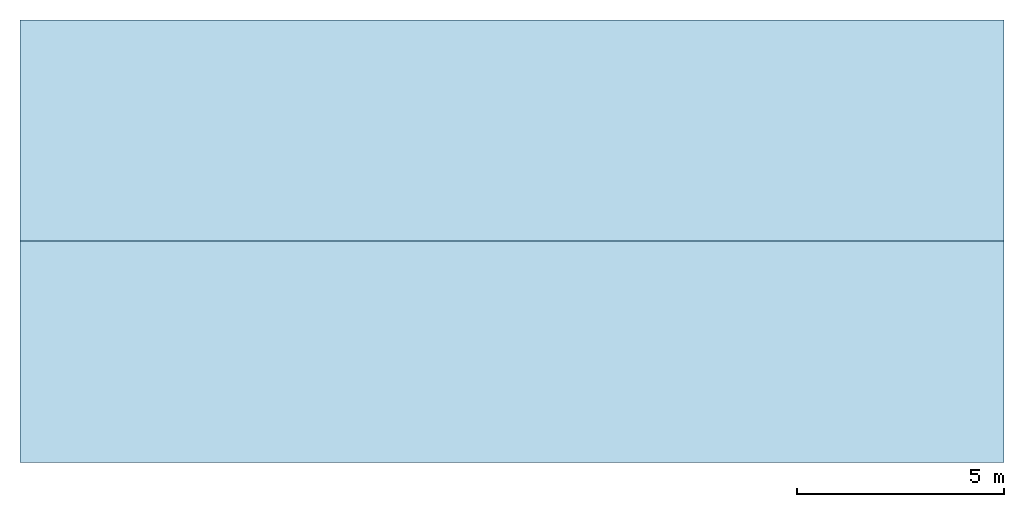
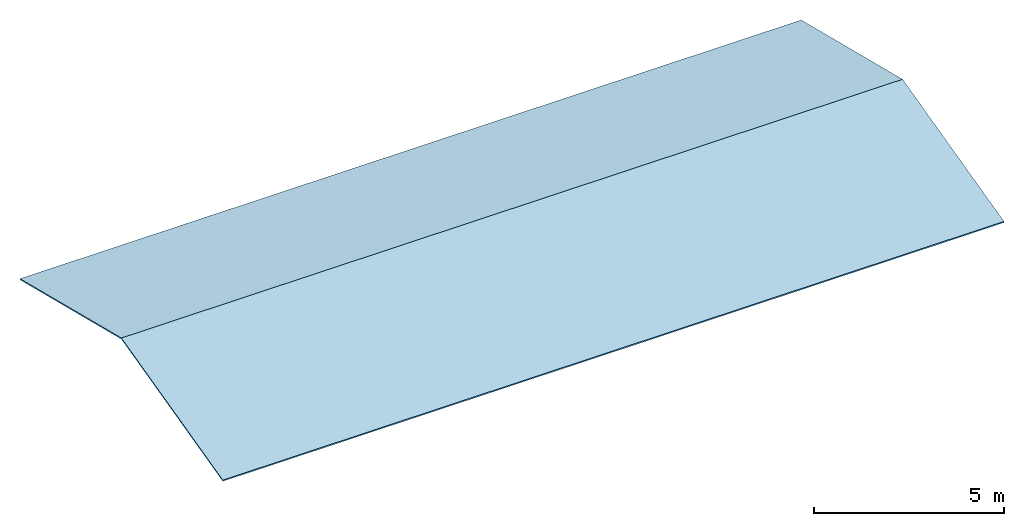
# One storey: 2 slabs, 1 element without a shape of its own.
"""IFC2X3 building model written with IfcOpenShell, lengths in millimetres."""

from ifc_helpers import new_model, entity, si_unit, converted_unit, derived_unit, direction, frame, frame_2d, origin, place, context, subcontext, project, spatial, rectangle, extrude, type_object, element, aggregate, save


model = new_model("IFC2X3")

# Units and contexts
model_context = context("Model", 3, precision=0.01, world=origin(), true_north=direction((6.12303176911189e-17, 1.0)))
body_context = subcontext(model_context, "Body", "Model", "MODEL_VIEW")
ifc_project = project(units=[si_unit("LENGTHUNIT", "METRE", prefix="MILLI"), si_unit("AREAUNIT", "SQUARE_METRE"), si_unit("VOLUMEUNIT", "CUBIC_METRE"), converted_unit("PLANEANGLEUNIT", "DEGREE", entity("IfcRatioMeasure", 0.0174532925199433), si_unit("PLANEANGLEUNIT", "RADIAN"), dimensions=[0, 0, 0, 0, 0, 0, 0]), si_unit("MASSUNIT", "GRAM", prefix="KILO"), derived_unit("MASSDENSITYUNIT", [(si_unit("MASSUNIT", "GRAM", prefix="KILO"), 1), (si_unit("LENGTHUNIT", "METRE"), -3)]), derived_unit("MOMENTOFINERTIAUNIT", [(si_unit("LENGTHUNIT", "METRE"), 4)]), si_unit("TIMEUNIT", "SECOND"), si_unit("FREQUENCYUNIT", "HERTZ"), si_unit("THERMODYNAMICTEMPERATUREUNIT", "DEGREE_CELSIUS"), derived_unit("THERMALTRANSMITTANCEUNIT", [(si_unit("MASSUNIT", "GRAM", prefix="KILO"), 1), (si_unit("THERMODYNAMICTEMPERATUREUNIT", "KELVIN"), -1), (si_unit("TIMEUNIT", "SECOND"), -3)]), derived_unit("VOLUMETRICFLOWRATEUNIT", [(si_unit("LENGTHUNIT", "METRE"), 3), (si_unit("TIMEUNIT", "SECOND"), -1)]), si_unit("ELECTRICCURRENTUNIT", "AMPERE"), si_unit("ELECTRICVOLTAGEUNIT", "VOLT"), si_unit("POWERUNIT", "WATT"), si_unit("FORCEUNIT", "NEWTON", prefix="KILO"), si_unit("ILLUMINANCEUNIT", "LUX"), si_unit("LUMINOUSFLUXUNIT", "LUMEN"), si_unit("LUMINOUSINTENSITYUNIT", "CANDELA"), derived_unit("USERDEFINED", [(si_unit("MASSUNIT", "GRAM", prefix="KILO"), -1), (si_unit("LENGTHUNIT", "METRE"), -2), (si_unit("TIMEUNIT", "SECOND"), 3), (si_unit("LUMINOUSFLUXUNIT", "LUMEN"), 1)]), derived_unit("LINEARVELOCITYUNIT", [(si_unit("LENGTHUNIT", "METRE"), 1), (si_unit("TIMEUNIT", "SECOND"), -1)]), si_unit("PRESSUREUNIT", "PASCAL"), derived_unit("USERDEFINED", [(si_unit("LENGTHUNIT", "METRE"), -2), (si_unit("MASSUNIT", "GRAM", prefix="KILO"), 1), (si_unit("TIMEUNIT", "SECOND"), -2)]), derived_unit("LINEARFORCEUNIT", [(si_unit("MASSUNIT", "GRAM", prefix="KILO"), 1), (si_unit("LENGTHUNIT", "METRE"), 1), (si_unit("TIMEUNIT", "SECOND"), -2), (si_unit("LENGTHUNIT", "METRE"), -1)]), derived_unit("PLANARFORCEUNIT", [(si_unit("MASSUNIT", "GRAM", prefix="KILO"), 1), (si_unit("LENGTHUNIT", "METRE"), 1), (si_unit("TIMEUNIT", "SECOND"), -2), (si_unit("LENGTHUNIT", "METRE"), -2)])], contexts=[model_context])

# Site, building, storey
site_placement = place(None, origin())
site = spatial("IfcSite", under=ifc_project, at=site_placement, CompositionType="ELEMENT")
building_placement = place(site_placement, origin())
building = spatial("IfcBuilding", under=site, at=building_placement, Name="Building Name", CompositionType="ELEMENT")
storey_placement = place(building_placement, frame((0.0, 0.0, 2400.0)))
storey = spatial("IfcBuildingStorey", under=building, at=storey_placement, Name="Floor 1", CompositionType="ELEMENT", Elevation=2400.0)

# Roof, slabs
roof_placement = place(storey_placement, frame((-8191.00617404031, -5358.31934762622, -149.596801705909)))
roof = element("IfcRoof", 1, at=roof_placement, inside=storey, Name="Basic Roof", ObjectType="Basic Roof", ShapeType="NOTDEFINED")
slab_type_1 = type_object("IfcSlabType", Name="Basic Roof", PredefinedType="ROOF")
slab_1_placement = place(roof_placement, origin())
slab_1 = element("IfcSlab", 2, at=slab_1_placement, type_object=slab_type_1, Name="Basic Roof", ObjectType="Basic Roof", PredefinedType="NOTDEFINED", context=body_context, shape_type="SweptSolid", body=[
    extrude(rectangle(XDim=23800.0, YDim=5513.78291702196, at=frame_2d((4.54747350886464e-12, -1.36424205265939e-12), x_axis=(1.0, 0.0))), frame((11900.0, 8025.0, 666.952407605509), z_axis=(0.0, 0.241921895599668, 0.970295726275996), x_axis=(1.0, 0.0, 0.0)), (0.0, -0.241921895599668, 0.970295726275996), 39.1633179152963),
])
slab_type_2 = type_object("IfcSlabType", Name="Basic Roof", PredefinedType="ROOF")
slab_2_placement = place(roof_placement, origin())
slab_2 = element("IfcSlab", 3, at=slab_2_placement, type_object=slab_type_2, Name="Basic Roof", ObjectType="Basic Roof", PredefinedType="NOTDEFINED", context=body_context, shape_type="SweptSolid", body=[
    extrude(rectangle(XDim=5513.78291702196, YDim=23799.9999999999, at=frame_2d((-1.09139364212751e-11, -1.36424205265939e-12), x_axis=(0.0, 1.0))), frame((11900.0, 2675.0, 666.952407605509), z_axis=(0.0, -0.241921895599668, 0.970295726275996), x_axis=(1.0, 0.0, 0.0)), (0.0, 0.241921895599668, 0.970295726275996), 39.1633179152963),
])
aggregate(roof, [slab_1, slab_2])

save(model, "model.ifc")
